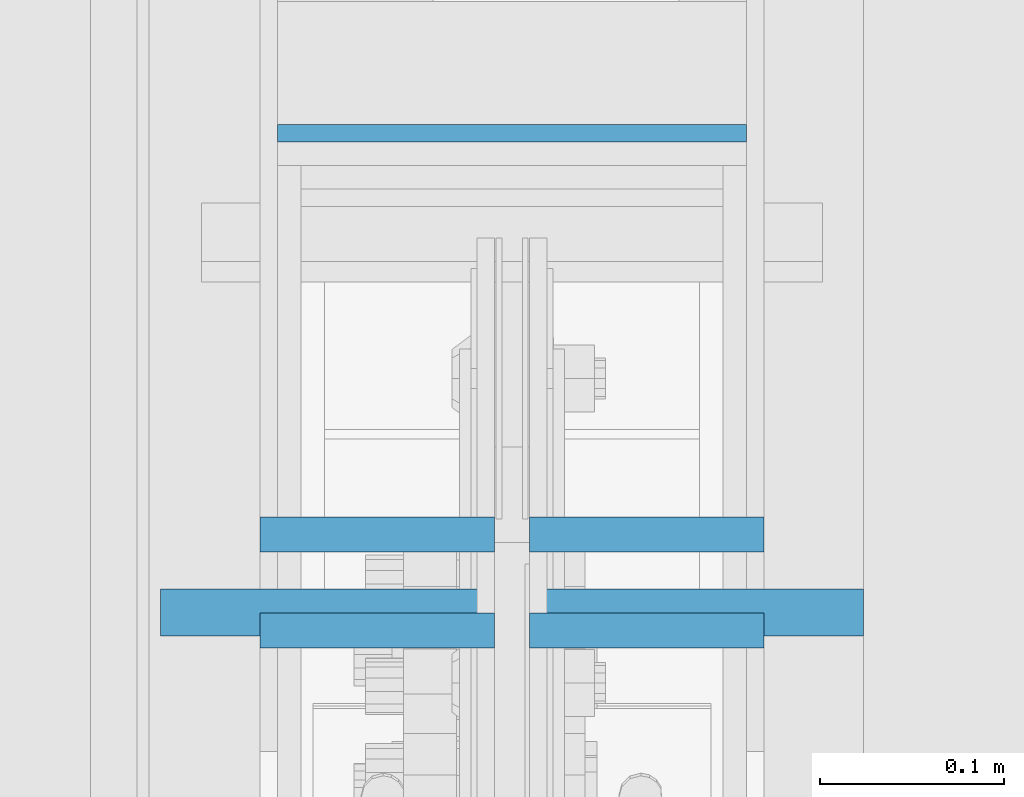
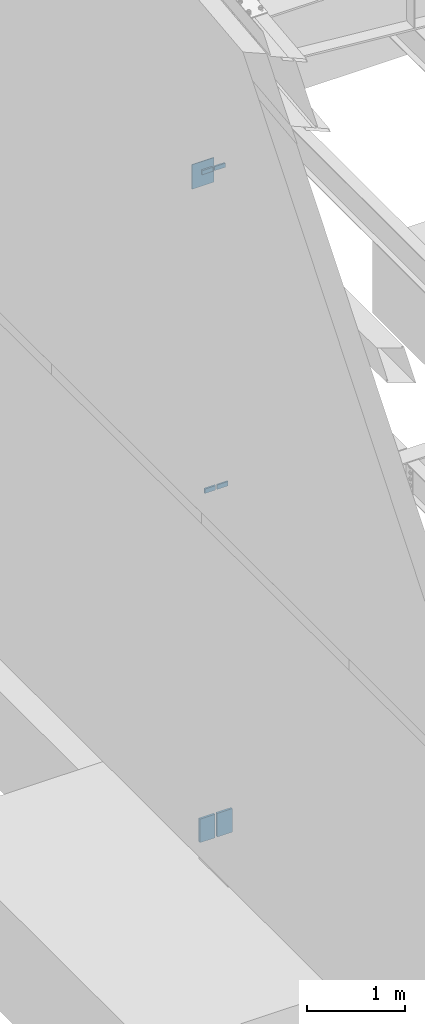
# One storey, part 389 of 1179: 7 columns, 4 elements without a shape of their own.
"""IFC2X3 building model written with IfcOpenShell, lengths in millimetres."""

from ifc_helpers import new_model, si_unit, frame, origin_with_axes, place, context, subcontext, project, spatial, faceted_brep, material, type_object, element, aggregate, save


model = new_model("IFC2X3")

# Units and contexts
model_context = context("Model", 3, precision=1e-05, world=origin_with_axes())
body_context = subcontext(model_context, "Body", "Model", "MODEL_VIEW")
ifc_project = project(units=[si_unit("LENGTHUNIT", "METRE", prefix="MILLI"), si_unit("AREAUNIT", "SQUARE_METRE"), si_unit("VOLUMEUNIT", "CUBIC_METRE"), si_unit("MASSUNIT", "GRAM", prefix="KILO"), si_unit("TIMEUNIT", "SECOND"), si_unit("PLANEANGLEUNIT", "RADIAN"), si_unit("SOLIDANGLEUNIT", "STERADIAN"), si_unit("THERMODYNAMICTEMPERATUREUNIT", "DEGREE_CELSIUS"), si_unit("LUMINOUSINTENSITYUNIT", "LUMEN")], contexts=[model_context])

# Site, building, storey
site_placement = place(None, origin_with_axes())
site = spatial("IfcSite", under=ifc_project, at=site_placement, CompositionType="ELEMENT")
building_placement = place(site_placement, origin_with_axes())
building = spatial("IfcBuilding", under=site, at=building_placement, Name="Undefined", CompositionType="ELEMENT")
storey_placement = place(building_placement, origin_with_axes())
storey = spatial("IfcBuildingStorey", under=building, at=storey_placement, Name="Undefined", CompositionType="ELEMENT", Elevation=0.0)

# Assembly, column
assembly_1_placement = place(storey_placement, origin_with_axes())
assembly_1 = element("IfcElementAssembly", 1, at=assembly_1_placement, inside=storey, Name="BEAM", AssemblyPlace="NOTDEFINED", PredefinedType="RIGID_FRAME")
ifc_material_1 = material(Name="STEEL/A36")
column_type_1 = type_object("IfcColumnType", PredefinedType="NOTDEFINED")
column_1_placement = place(assembly_1_placement, frame((431.800000000005, 12202.9376974615, 7708.9), z_axis=(1.0, 0.0, 0.0), x_axis=(0.0, 0.0, 1.0)))
column_1 = element("IfcColumn", 2, at=column_1_placement, type_object=column_type_1, material=ifc_material_1, Name="PLATE", context=body_context, shape_type="Brep", body=[
    faceted_brep([(0.0, 4.76249999999982, -127.0), (0.0, 4.76249999999709, 127.0), (304.799999999999, 4.76249999999982, 127.0), (304.799999999999, 4.76249999999982, -127.0), (0.0, -4.76249999999709, 127.0), (304.799999999999, -4.76249999999982, 127.0), (0.0, -4.76249999999982, -127.0), (304.799999999999, -4.76249999999982, -127.0)], [[[0, 1, 2, 3]], [[1, 4, 5, 2]], [[4, 6, 7, 5]], [[6, 0, 3, 7]], [[5, 7, 3, 2]], [[6, 4, 1, 0]]]),
])
aggregate(assembly_1, [column_1])

# Assembly, columns
assembly_2_placement = place(storey_placement, origin_with_axes())
assembly_2 = element("IfcElementAssembly", 3, at=assembly_2_placement, inside=storey, Name="COLUMN", AssemblyPlace="NOTDEFINED", PredefinedType="RIGID_FRAME")
ifc_material_2 = material(Name="STEEL/A572-GR.50")
column_type_2 = type_object("IfcColumnType", PredefinedType="NOTDEFINED")
column_2_placement = place(assembly_2_placement, frame((358.774999999999, 11985.4501974615, 8026.4), z_axis=(-1.0, 0.0, 0.0), x_axis=(0.0, 0.0, 1.0)))
column_2 = element("IfcColumn", 4, at=column_2_placement, type_object=column_type_2, material=ifc_material_2, Name="PLATE", context=body_context, shape_type="Brep", body=[
    faceted_brep([(0.0, 9.52500000000146, -63.5), (0.0, 9.52500000000146, 63.5), (50.8000000000002, 9.52500000000146, 63.5), (50.8000000000002, 9.52500000000146, -63.5), (0.0, -9.52500000000146, 63.5), (50.8000000000002, -9.52500000000146, 63.5), (0.0, -9.52500000000146, -63.5), (50.8000000000002, -9.52500000000146, -63.5)], [[[0, 1, 2, 3]], [[1, 4, 5, 2]], [[4, 6, 7, 5]], [[6, 0, 3, 7]], [[5, 7, 3, 2]], [[6, 4, 1, 0]]]),
])
column_3_placement = place(assembly_2_placement, frame((504.824999999999, 11985.4501974615, 8026.4), z_axis=(-1.0, 0.0, 0.0), x_axis=(0.0, 0.0, 1.0)))
column_3 = element("IfcColumn", 5, at=column_3_placement, type_object=column_type_2, material=ifc_material_2, Name="PLATE", context=body_context, shape_type="Brep", body=[
    faceted_brep([(0.0, 9.52500000000146, -63.5), (0.0, 9.52500000000146, 63.5), (50.8000000000002, 9.52500000000146, 63.5), (50.8000000000002, 9.52500000000146, -63.5), (0.0, -9.52500000000146, 63.5), (50.8000000000002, -9.52500000000146, 63.5), (0.0, -9.52500000000146, -63.5), (50.8000000000002, -9.52500000000146, -63.5)], [[[0, 1, 2, 3]], [[1, 4, 5, 2]], [[4, 6, 7, 5]], [[6, 0, 3, 7]], [[5, 7, 3, 2]], [[6, 4, 1, 0]]]),
])

# Assembly, column
assembly_3_placement = place(storey_placement, origin_with_axes())
assembly_3 = element("IfcElementAssembly", 6, at=assembly_3_placement, inside=storey, Name="PLATE", AssemblyPlace="NOTDEFINED", PredefinedType="RIGID_FRAME")
column_type_3 = type_object("IfcColumnType", PredefinedType="NOTDEFINED")
column_4_placement = place(assembly_3_placement, frame((330.2, 11943.2331124363, -215.9), z_axis=(1.0, 0.0, 0.0), x_axis=(0.0, 0.0, 1.0)))
column_4 = element("IfcColumn", 7, at=column_4_placement, type_object=column_type_3, material=ifc_material_2, Name="PLATE", context=body_context, shape_type="Brep", body=[
    faceted_brep([(0.0, 12.6999999999998, -88.9000000000015), (0.0, 12.6999999999998, 88.9000000000015), (292.287947617165, 12.7000000000007, 88.9000000000015), (292.287947617165, 12.7000000000007, -88.9000000000015), (0.0, -12.6999999999998, 88.9000000000015), (292.287947617165, -12.7000000000007, 88.9000000000015), (0.0, -12.6999999999998, -88.9000000000015), (292.287947617165, -12.7000000000007, -88.9000000000015)], [[[0, 1, 2, 3]], [[1, 4, 5, 2]], [[4, 6, 7, 5]], [[6, 0, 3, 7]], [[5, 7, 3, 2]], [[6, 4, 1, 0]]]),
])
aggregate(assembly_3, [column_4])

assembly_4_placement = place(storey_placement, origin_with_axes())
assembly_4 = element("IfcElementAssembly", 8, at=assembly_4_placement, inside=storey, Name="PLATE", AssemblyPlace="NOTDEFINED", PredefinedType="RIGID_FRAME")
column_5_placement = place(assembly_4_placement, frame((533.4, 11943.2331124363, -215.9), z_axis=(-1.0, 0.0, 0.0), x_axis=(0.0, 0.0, 1.0)))
column_5 = element("IfcColumn", 9, at=column_5_placement, type_object=column_type_3, material=ifc_material_2, Name="PLATE", context=body_context, shape_type="Brep", body=[
    faceted_brep([(0.0, 12.6999999999998, -88.9000000000015), (0.0, 12.6999999999998, 88.9000000000015), (292.287947617165, 12.7000000000007, 88.9000000000015), (292.287947617165, 12.7000000000007, -88.9000000000015), (0.0, -12.6999999999998, 88.9000000000015), (292.287947617165, -12.7000000000007, 88.9000000000015), (0.0, -12.6999999999998, -88.9000000000015), (292.287947617165, -12.7000000000007, -88.9000000000015)], [[[0, 1, 2, 3]], [[1, 4, 5, 2]], [[4, 6, 7, 5]], [[6, 0, 3, 7]], [[5, 7, 3, 2]], [[6, 4, 1, 0]]]),
])
aggregate(assembly_4, [column_5])

# Column
column_type_4 = type_object("IfcColumnType", PredefinedType="NOTDEFINED")
column_6_placement = place(assembly_2_placement, frame((358.775000000002, 11933.5734303375, 4102.1), z_axis=(1.0, 0.0, 0.0), x_axis=(0.0, 0.0, 1.0)))
column_6 = element("IfcColumn", 10, at=column_6_placement, type_object=column_type_4, material=ifc_material_2, Name="PLATE", context=body_context, shape_type="Brep", body=[
    faceted_brep([(0.0, 9.52500000000146, -63.5), (0.0, 9.52500000000146, 63.5), (56.4906928705395, 9.52499999999964, 63.5), (56.4906928705395, 9.52499999999964, -63.5), (0.0, -9.52500000000146, 63.5), (56.4906928705395, -9.52499999999964, 63.5), (0.0, -9.52500000000146, -63.5), (56.4906928705395, -9.52499999999964, -63.5)], [[[0, 1, 2, 3]], [[1, 4, 5, 2]], [[4, 6, 7, 5]], [[6, 0, 3, 7]], [[5, 7, 3, 2]], [[6, 4, 1, 0]]]),
])

column_7_placement = place(assembly_2_placement, frame((504.825000000002, 11933.5734303375, 4102.1), z_axis=(-1.0, 0.0, 0.0), x_axis=(0.0, 0.0, 1.0)))
column_7 = element("IfcColumn", 11, at=column_7_placement, type_object=column_type_4, material=ifc_material_2, Name="PLATE", context=body_context, shape_type="Brep", body=[
    faceted_brep([(0.0, 9.52500000000146, -63.5), (0.0, 9.52500000000146, 63.5), (56.4906928705395, 9.52499999999964, 63.5), (56.4906928705395, 9.52499999999964, -63.5), (0.0, -9.52500000000146, 63.5), (56.4906928705395, -9.52499999999964, 63.5), (0.0, -9.52500000000146, -63.5), (56.4906928705395, -9.52499999999964, -63.5)], [[[0, 1, 2, 3]], [[1, 4, 5, 2]], [[4, 6, 7, 5]], [[6, 0, 3, 7]], [[5, 7, 3, 2]], [[6, 4, 1, 0]]]),
])

aggregate(assembly_2, [column_2, column_3, column_6, column_7])

save(model, "model.ifc")
